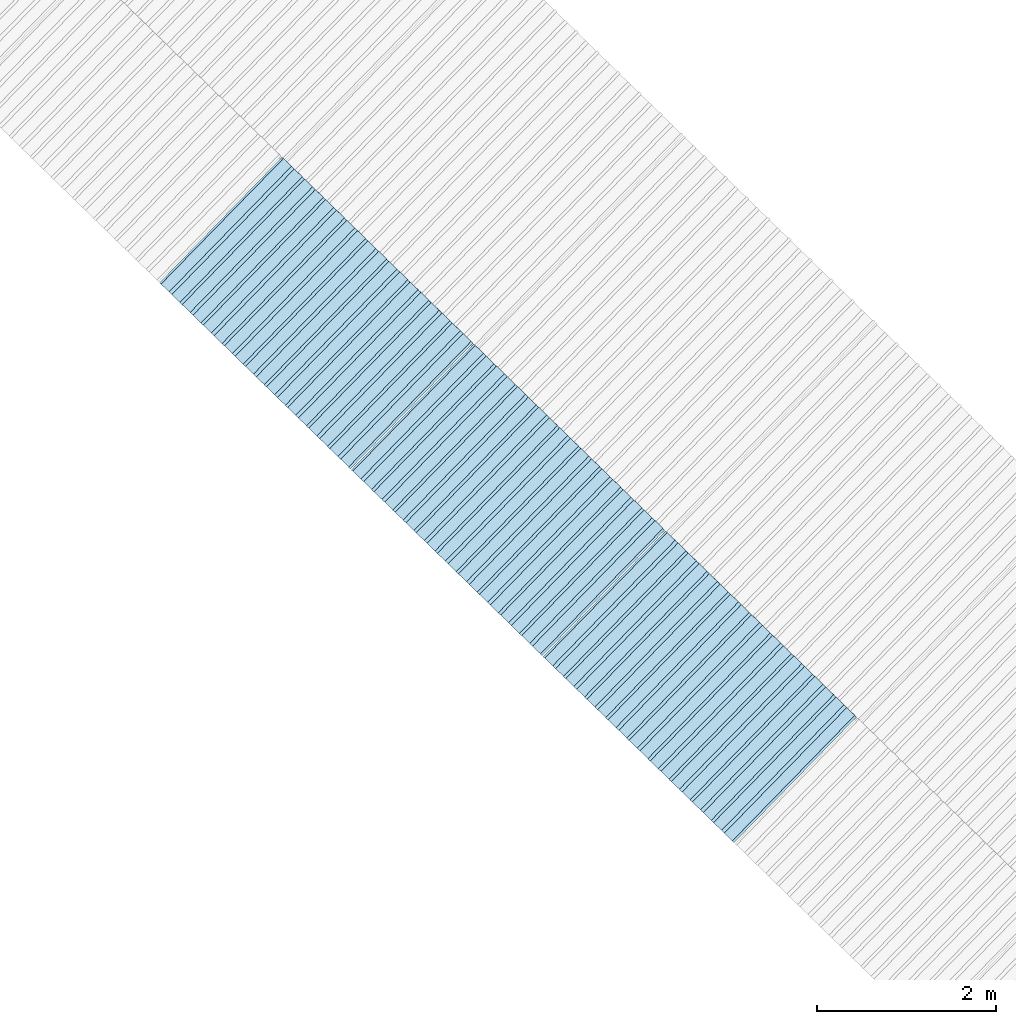
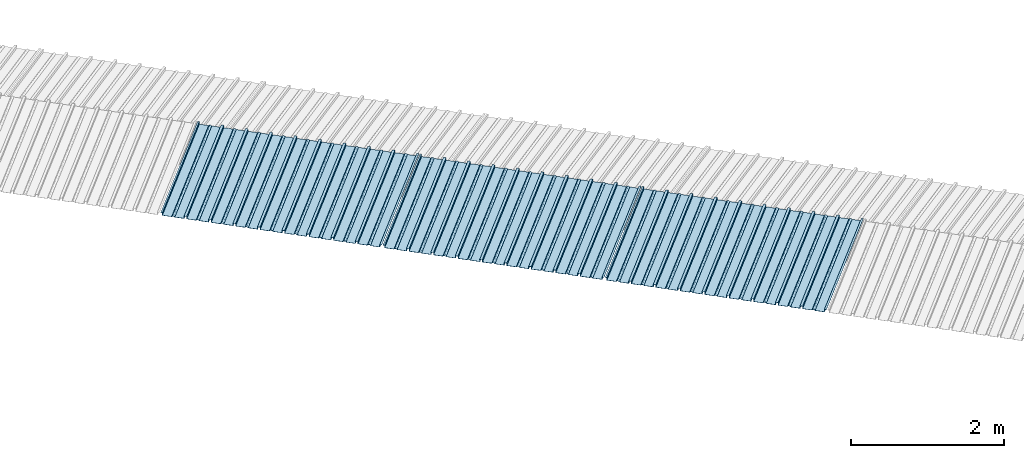
# One storey, part 1 of 8: 3 plates, 1 element without a shape of its own.
"""IFC4 building model written with IfcOpenShell, lengths in metres."""

from ifc_helpers import new_model, entity, si_unit, converted_unit, direction, frame, origin, place, context, subcontext, project, spatial, line, arc, indexed_curve, outline, extrude, source, transform, mapped, material, type_object, type_shapes, element, aggregate, save


model = new_model("IFC4")

# Units and contexts
model_context = context("Model", 3, precision=1e-05, world=origin(), true_north=direction((6.123233995736766e-17, 1.0)))
body_context = subcontext(model_context, "Body", "Model", "MODEL_VIEW")
ifc_project = project(units=[si_unit("LENGTHUNIT", "METRE"), si_unit("AREAUNIT", "SQUARE_METRE"), si_unit("VOLUMEUNIT", "CUBIC_METRE"), converted_unit("PLANEANGLEUNIT", "DEGREE", entity("IfcPlaneAngleMeasure", 0.017453292519943278), si_unit("PLANEANGLEUNIT", "RADIAN"), dimensions=[0, 0, 0, 0, 0, 0, 0])], contexts=[model_context])

# Site, building, storey
site_placement = place(None, frame((0.0, 0.0, 0.0), z_axis=(0.0, 0.0, 1.0), x_axis=(0.7160934825303189, -0.6980043870045516, 0.0)))
site = spatial("IfcSite", under=ifc_project, at=site_placement, CompositionType="ELEMENT")
building_placement = place(site_placement, origin())
building = spatial("IfcBuilding", under=site, at=building_placement, CompositionType="ELEMENT")
storey_placement = place(building_placement, frame((0.0, 0.0, -1.24)))
storey = spatial("IfcBuildingStorey", under=building, at=storey_placement, Name="Livello 5", CompositionType="ELEMENT", Elevation=-1.24)

# Roof, plates
curtain_wall_type = type_object("IfcCurtainWallType", Name="Vetrata Copertura 2", PredefinedType="NOTDEFINED")
roof_placement = place(storey_placement, frame((0.0, 0.0, 1.24)))
roof = element("IfcRoof", 1, at=roof_placement, inside=storey, type_object=curtain_wall_type, Name="Vetrata Copertura 2", ObjectType="Vetrata Copertura 2", PredefinedType="SHED_ROOF")
ifc_material = material(Name="Default")
plate_type_1 = type_object("IfcPlateType", Name="Pannello copertura:Pannello copertura", PredefinedType="CURTAIN_PANEL", material=ifc_material)
shared_shape_1 = source(origin(), body_context, "Body", "SweptSolid", [
    extrude(outline(indexed_curve([(1.339910560042256, -0.015785714285718594), (1.4699105600422562, -0.015785714285719003), (1.4699105600422562, 0.024214285714281004), (1.494919197675959, 0.02421428571428092), (1.494919197675959, 0.027214285714280917), (1.466910560042256, 0.027214285714281014), (1.466910560042256, -0.012785714285718995), (1.3417510978483753, -0.012785714285718492), (1.3199105600422556, 4.9134324369942785e-05), (1.2980700222361363, -0.012785714285718328), (1.1729105600422558, -0.01278571428571804), (1.1729105600422558, 0.02721428571428197), (1.136910560042256, 0.027214285714282097), (1.136910560042256, -0.012785714285717937), (1.0117510978483748, -0.01278571428571754), (0.9899105600422554, 4.913432437100935e-05), (0.968070022236136, -0.01278571428571726), (0.8429105600422558, -0.012785714285716971), (0.842910560042256, 0.027214285714283023), (0.8069105600422554, 0.027214285714283144), (0.8069105600422554, -0.01278571428571687), (0.6817510978483748, -0.012785714285716475), (0.6599105600422555, 4.9134324372075926e-05), (0.6380700222361361, -0.012785714285716196), (0.5129105600422553, -0.012785714285715915), (0.5129105600422554, 0.027214285714284105), (0.47691056004225557, 0.027214285714284227), (0.47691056004225557, -0.012785714285715804), (0.3517510978483749, -0.012785714285715427), (0.32991056004225544, 4.9134324373142496e-05), (0.3080700222361361, -0.012785714285715127), (0.18291056004225528, -0.012785714285714848), (0.18291056004225553, 0.027214285714285157), (0.1469105600422553, 0.02721428571428528), (0.14691056004225533, -0.012785714285714738), (0.021751097848374697, -0.01278571428571434), (-8.943995774469983e-05, 4.913432437420907e-05), (-0.021929977763864118, -0.01278571428571406), (-0.1470894399577447, -0.012785714285713783), (-0.14708943995774473, 0.02721428571428624), (-0.18308943995774493, 0.027214285714286364), (-0.1830894399577449, -0.012785714285713672), (-0.30824890215162537, -0.012785714285713215), (-0.33008943995774487, 4.9134324375275644e-05), (-0.3519299777638641, -0.012785714285712995), (-0.47708943995774494, -0.012785714285712714), (-0.4770894399577447, 0.02721428571428729), (-0.5130894399577449, 0.02721428571428741), (-0.5130894399577449, -0.012785714285712603), (-0.6382489021516256, -0.012785714285712207), (-0.6600894399577448, 4.9134324376342214e-05), (-0.6819299777638644, -0.012785714285711926), (-0.8070894399577453, -0.012785714285711647), (-0.807089439957745, 0.027214285714288373), (-0.843089439957745, 0.027214285714288494), (-0.8430894399577447, -0.012785714285711538), (-0.968248902151626, -0.012785714285711083), (-0.9900894399577453, 4.9134324377408785e-05), (-1.0119299777638646, -0.012785714285710861), (-1.1370894399577456, -0.012785714285710582), (-1.1370894399577451, 0.02721428571428942), (-1.1730894399577452, 0.027214285714289545), (-1.1730894399577454, -0.012785714285710473), (-1.2982489021516257, -0.012785714285710093), (-1.3200894399577452, 4.9134324378475355e-05), (-1.3419299777638647, -0.012785714285709794), (-1.4670894399577457, -0.012785714285709513), (-1.4670894399577454, 0.027214285714290503), (-1.490089439957745, 0.027214285714290586), (-1.490089439957745, 0.024214285714290556), (-1.4700894399577447, 0.02421428571429049), (-1.4700894399577449, -0.015785714285709514), (-1.3400894399577452, -0.015785714285709924), (-1.3200894399577452, -0.0029508656756215236), (-1.3000894399577452, -0.015785714285710063), (-1.170089439957745, -0.015785714285710472), (-1.1700894399577453, 0.024214285714289543), (-1.140089439957745, 0.02421428571428944), (-1.1400894399577455, -0.015785714285710583), (-1.0100894399577454, -0.015785714285710992), (-0.9900894399577453, -0.00295086567562259), (-0.9700894399577453, -0.015785714285711128), (-0.8400894399577448, -0.01578571428571154), (-0.8400894399577451, 0.024214285714288453), (-0.8100894399577452, 0.024214285714288356), (-0.8100894399577452, -0.015785714285711648), (-0.6800894399577451, -0.015785714285712012), (-0.6600894399577448, -0.0029508656756236573), (-0.6400894399577448, -0.015785714285712196), (-0.5100894399577451, -0.015785714285712606), (-0.5100894399577451, 0.024214285714287406), (-0.4800894399577449, 0.024214285714287305), (-0.4800894399577449, -0.015785714285712713), (-0.350089439957745, -0.01578571428571316), (-0.33008943995774487, -0.0029508656756247237), (-0.31008943995774485, -0.01578571428571326), (-0.1800894399577448, -0.015785714285713674), (-0.1800894399577448, 0.024214285714286323), (-0.1500894399577446, 0.02421428571428622), (-0.15008943995774485, -0.015785714285713782), (-0.020089439957744877, -0.015785714285714264), (-8.943995774473269e-05, -0.00295086567562579), (0.01991056004225521, -0.015785714285714323), (0.14991056004225545, -0.01578571428571474), (0.14991056004225542, 0.024214285714285272), (0.17991056004225567, 0.02421428571428517), (0.1799105600422554, -0.01578571428571485), (0.30991056004225526, -0.01578571428571532), (0.32991056004225544, -0.0029508656756268565), (0.3499105600422554, -0.015785714285715395), (0.47991056004225535, -0.015785714285715804), (0.47991056004225535, 0.02421428571428419), (0.5099105600422553, 0.02421428571428409), (0.5099105600422552, -0.015785714285715916), (0.6399105600422554, -0.015785714285716325), (0.6599105600422555, -0.002950865675627923), (0.6799105600422555, -0.01578571428571646), (0.8099105600422557, -0.015785714285716873), (0.8099105600422557, 0.02421428571428314), (0.8399105600422555, 0.02421428571428304), (0.8399105600422554, -0.015785714285716974), (0.9699105600422554, -0.015785714285717393), (0.9899105600422554, -0.0029508656756289894), (1.0099105600422555, -0.01578571428571753), (1.1399105600422557, -0.015785714285717938), (1.1399105600422557, 0.024214285714282077), (1.169910560042256, 0.024214285714281972), (1.1699105600422557, -0.01578571428571804), (1.2999105600422558, -0.01578571428571846), (1.3199105600422558, -0.0029508656756300567)], segments=[line(1, 2, 3, 4, 5, 6, 7, 8), arc(8, 9, 10), line(10, 11, 12, 13, 14, 15), arc(15, 16, 17), line(17, 18, 19, 20, 21, 22), arc(22, 23, 24), line(24, 25, 26, 27, 28, 29), arc(29, 30, 31), line(31, 32, 33, 34, 35, 36), arc(36, 37, 38), line(38, 39, 40, 41, 42, 43), arc(43, 44, 45), line(45, 46, 47, 48, 49, 50), arc(50, 51, 52), line(52, 53, 54, 55, 56, 57), arc(57, 58, 59), line(59, 60, 61, 62, 63, 64), arc(64, 65, 66), line(66, 67, 68, 69, 70, 71, 72, 73), arc(73, 74, 75), line(75, 76, 77, 78, 79, 80), arc(80, 81, 82), line(82, 83, 84, 85, 86, 87), arc(87, 88, 89), line(89, 90, 91, 92, 93, 94), arc(94, 95, 96), line(96, 97, 98, 99, 100, 101), arc(101, 102, 103), line(103, 104, 105, 106, 107, 108), arc(108, 109, 110), line(110, 111, 112, 113, 114, 115), arc(115, 116, 117), line(117, 118, 119, 120, 121, 122), arc(122, 123, 124), line(124, 125, 126, 127, 128, 129), arc(129, 130, 1)], self_intersect=False)), frame((8.080232403624576e-05, -0.015785714285719014, 0.0), z_axis=(0.0, 0.0, -1.0), x_axis=(1.0, 0.0, 0.0)), (0.0, 0.0, -1.0), 1.9691142879617602),
])
type_shapes(plate_type_1, [shared_shape_1])
plate_1_placement = place(roof_placement, frame((-11.232115726538199, -6.922854376535778, -1.0800000000000003), z_axis=(0.0, 0.9980594686585702, 0.0622679453729828), x_axis=(1.0, 0.0, 0.0)))
plate_1 = element("IfcPlate", 2, at=plate_1_placement, type_object=plate_type_1, material=ifc_material, Name="Pannello copertura:Pannello copertura", ObjectType="Pannello copertura:Pannello copertura", PredefinedType="CURTAIN_PANEL", context=body_context, shape_type="MappedRepresentation", body=[
    mapped(shared_shape_1, transform((0.0, 0.0, 0.0), scale=1.0)),
])
plate_type_2 = type_object("IfcPlateType", Name="Pannello copertura:Pannello copertura", PredefinedType="CURTAIN_PANEL", material=ifc_material)
shared_shape_2 = source(origin(), body_context, "Body", "SweptSolid", [
    extrude(outline(indexed_curve([(1.339910560042256, -0.015785714285718594), (1.4699105600422562, -0.015785714285719003), (1.4699105600422562, 0.024214285714281004), (1.494919197675959, 0.02421428571428092), (1.494919197675959, 0.027214285714280917), (1.466910560042256, 0.027214285714281014), (1.466910560042256, -0.012785714285718995), (1.3417510978483753, -0.012785714285718492), (1.3199105600422556, 4.9134324369942785e-05), (1.2980700222361363, -0.012785714285718328), (1.1729105600422558, -0.01278571428571804), (1.1729105600422558, 0.02721428571428197), (1.136910560042256, 0.027214285714282097), (1.136910560042256, -0.012785714285717937), (1.0117510978483748, -0.01278571428571754), (0.9899105600422554, 4.913432437100935e-05), (0.968070022236136, -0.01278571428571726), (0.8429105600422558, -0.012785714285716971), (0.842910560042256, 0.027214285714283023), (0.8069105600422554, 0.027214285714283144), (0.8069105600422554, -0.01278571428571687), (0.6817510978483748, -0.012785714285716475), (0.6599105600422555, 4.9134324372075926e-05), (0.6380700222361361, -0.012785714285716196), (0.5129105600422553, -0.012785714285715915), (0.5129105600422554, 0.027214285714284105), (0.47691056004225557, 0.027214285714284227), (0.47691056004225557, -0.012785714285715804), (0.3517510978483749, -0.012785714285715427), (0.32991056004225544, 4.9134324373142496e-05), (0.3080700222361361, -0.012785714285715127), (0.18291056004225528, -0.012785714285714848), (0.18291056004225553, 0.027214285714285157), (0.1469105600422553, 0.02721428571428528), (0.14691056004225533, -0.012785714285714738), (0.021751097848374697, -0.01278571428571434), (-8.943995774469983e-05, 4.913432437420907e-05), (-0.021929977763864118, -0.01278571428571406), (-0.1470894399577447, -0.012785714285713783), (-0.14708943995774473, 0.02721428571428624), (-0.18308943995774493, 0.027214285714286364), (-0.1830894399577449, -0.012785714285713672), (-0.30824890215162537, -0.012785714285713215), (-0.33008943995774487, 4.9134324375275644e-05), (-0.3519299777638641, -0.012785714285712995), (-0.47708943995774494, -0.012785714285712714), (-0.4770894399577447, 0.02721428571428729), (-0.5130894399577449, 0.02721428571428741), (-0.5130894399577449, -0.012785714285712603), (-0.6382489021516256, -0.012785714285712207), (-0.6600894399577448, 4.9134324376342214e-05), (-0.6819299777638644, -0.012785714285711926), (-0.8070894399577453, -0.012785714285711647), (-0.807089439957745, 0.027214285714288373), (-0.843089439957745, 0.027214285714288494), (-0.8430894399577447, -0.012785714285711538), (-0.968248902151626, -0.012785714285711083), (-0.9900894399577453, 4.9134324377408785e-05), (-1.0119299777638646, -0.012785714285710861), (-1.1370894399577456, -0.012785714285710582), (-1.1370894399577451, 0.02721428571428942), (-1.1730894399577452, 0.027214285714289545), (-1.1730894399577454, -0.012785714285710473), (-1.2982489021516257, -0.012785714285710093), (-1.3200894399577452, 4.9134324378475355e-05), (-1.3419299777638647, -0.012785714285709794), (-1.4670894399577457, -0.012785714285709513), (-1.4670894399577454, 0.027214285714290503), (-1.490089439957745, 0.027214285714290586), (-1.490089439957745, 0.024214285714290556), (-1.4700894399577447, 0.02421428571429049), (-1.4700894399577449, -0.015785714285709514), (-1.3400894399577452, -0.015785714285709924), (-1.3200894399577452, -0.0029508656756215236), (-1.3000894399577452, -0.015785714285710063), (-1.170089439957745, -0.015785714285710472), (-1.1700894399577453, 0.024214285714289543), (-1.140089439957745, 0.02421428571428944), (-1.1400894399577455, -0.015785714285710583), (-1.0100894399577454, -0.015785714285710992), (-0.9900894399577453, -0.00295086567562259), (-0.9700894399577453, -0.015785714285711128), (-0.8400894399577448, -0.01578571428571154), (-0.8400894399577451, 0.024214285714288453), (-0.8100894399577452, 0.024214285714288356), (-0.8100894399577452, -0.015785714285711648), (-0.6800894399577451, -0.015785714285712012), (-0.6600894399577448, -0.0029508656756236573), (-0.6400894399577448, -0.015785714285712196), (-0.5100894399577451, -0.015785714285712606), (-0.5100894399577451, 0.024214285714287406), (-0.4800894399577449, 0.024214285714287305), (-0.4800894399577449, -0.015785714285712713), (-0.350089439957745, -0.01578571428571316), (-0.33008943995774487, -0.0029508656756247237), (-0.31008943995774485, -0.01578571428571326), (-0.1800894399577448, -0.015785714285713674), (-0.1800894399577448, 0.024214285714286323), (-0.1500894399577446, 0.02421428571428622), (-0.15008943995774485, -0.015785714285713782), (-0.020089439957744877, -0.015785714285714264), (-8.943995774473269e-05, -0.00295086567562579), (0.01991056004225521, -0.015785714285714323), (0.14991056004225545, -0.01578571428571474), (0.14991056004225542, 0.024214285714285272), (0.17991056004225567, 0.02421428571428517), (0.1799105600422554, -0.01578571428571485), (0.30991056004225526, -0.01578571428571532), (0.32991056004225544, -0.0029508656756268565), (0.3499105600422554, -0.015785714285715395), (0.47991056004225535, -0.015785714285715804), (0.47991056004225535, 0.02421428571428419), (0.5099105600422553, 0.02421428571428409), (0.5099105600422552, -0.015785714285715916), (0.6399105600422554, -0.015785714285716325), (0.6599105600422555, -0.002950865675627923), (0.6799105600422555, -0.01578571428571646), (0.8099105600422557, -0.015785714285716873), (0.8099105600422557, 0.02421428571428314), (0.8399105600422555, 0.02421428571428304), (0.8399105600422554, -0.015785714285716974), (0.9699105600422554, -0.015785714285717393), (0.9899105600422554, -0.0029508656756289894), (1.0099105600422555, -0.01578571428571753), (1.1399105600422557, -0.015785714285717938), (1.1399105600422557, 0.024214285714282077), (1.169910560042256, 0.024214285714281972), (1.1699105600422557, -0.01578571428571804), (1.2999105600422558, -0.01578571428571846), (1.3199105600422558, -0.0029508656756300567)], segments=[line(1, 2, 3, 4, 5, 6, 7, 8), arc(8, 9, 10), line(10, 11, 12, 13, 14, 15), arc(15, 16, 17), line(17, 18, 19, 20, 21, 22), arc(22, 23, 24), line(24, 25, 26, 27, 28, 29), arc(29, 30, 31), line(31, 32, 33, 34, 35, 36), arc(36, 37, 38), line(38, 39, 40, 41, 42, 43), arc(43, 44, 45), line(45, 46, 47, 48, 49, 50), arc(50, 51, 52), line(52, 53, 54, 55, 56, 57), arc(57, 58, 59), line(59, 60, 61, 62, 63, 64), arc(64, 65, 66), line(66, 67, 68, 69, 70, 71, 72, 73), arc(73, 74, 75), line(75, 76, 77, 78, 79, 80), arc(80, 81, 82), line(82, 83, 84, 85, 86, 87), arc(87, 88, 89), line(89, 90, 91, 92, 93, 94), arc(94, 95, 96), line(96, 97, 98, 99, 100, 101), arc(101, 102, 103), line(103, 104, 105, 106, 107, 108), arc(108, 109, 110), line(110, 111, 112, 113, 114, 115), arc(115, 116, 117), line(117, 118, 119, 120, 121, 122), arc(122, 123, 124), line(124, 125, 126, 127, 128, 129), arc(129, 130, 1)], self_intersect=False)), frame((8.080232403624576e-05, -0.015785714285719014, 0.0), z_axis=(0.0, 0.0, -1.0), x_axis=(1.0, 0.0, 0.0)), (0.0, 0.0, -1.0), 1.9691142879617602),
])
type_shapes(plate_type_2, [shared_shape_2])
plate_2_placement = place(roof_placement, frame((-8.232110386186008, -6.922854376535778, -1.0800000000000003), z_axis=(0.0, 0.9980594686585702, 0.0622679453729828), x_axis=(1.0, 0.0, 0.0)))
plate_2 = element("IfcPlate", 3, at=plate_2_placement, type_object=plate_type_2, material=ifc_material, Name="Pannello copertura:Pannello copertura", ObjectType="Pannello copertura:Pannello copertura", PredefinedType="CURTAIN_PANEL", context=body_context, shape_type="MappedRepresentation", body=[
    mapped(shared_shape_2, transform((0.0, 0.0, 0.0), scale=1.0)),
])
plate_type_3 = type_object("IfcPlateType", Name="Pannello copertura:Pannello copertura", PredefinedType="CURTAIN_PANEL", material=ifc_material)
shared_shape_3 = source(origin(), body_context, "Body", "SweptSolid", [
    extrude(outline(indexed_curve([(1.339910560042256, -0.015785714285718594), (1.4699105600422562, -0.015785714285719003), (1.4699105600422562, 0.024214285714281004), (1.494919197675959, 0.02421428571428092), (1.494919197675959, 0.027214285714280917), (1.466910560042256, 0.027214285714281014), (1.466910560042256, -0.012785714285718995), (1.3417510978483753, -0.012785714285718492), (1.3199105600422556, 4.9134324369942785e-05), (1.2980700222361363, -0.012785714285718328), (1.1729105600422558, -0.01278571428571804), (1.1729105600422558, 0.02721428571428197), (1.136910560042256, 0.027214285714282097), (1.136910560042256, -0.012785714285717937), (1.0117510978483748, -0.01278571428571754), (0.9899105600422554, 4.913432437100935e-05), (0.968070022236136, -0.01278571428571726), (0.8429105600422558, -0.012785714285716971), (0.842910560042256, 0.027214285714283023), (0.8069105600422554, 0.027214285714283144), (0.8069105600422554, -0.01278571428571687), (0.6817510978483748, -0.012785714285716475), (0.6599105600422555, 4.9134324372075926e-05), (0.6380700222361361, -0.012785714285716196), (0.5129105600422553, -0.012785714285715915), (0.5129105600422554, 0.027214285714284105), (0.47691056004225557, 0.027214285714284227), (0.47691056004225557, -0.012785714285715804), (0.3517510978483749, -0.012785714285715427), (0.32991056004225544, 4.9134324373142496e-05), (0.3080700222361361, -0.012785714285715127), (0.18291056004225528, -0.012785714285714848), (0.18291056004225553, 0.027214285714285157), (0.1469105600422553, 0.02721428571428528), (0.14691056004225533, -0.012785714285714738), (0.021751097848374697, -0.01278571428571434), (-8.943995774469983e-05, 4.913432437420907e-05), (-0.021929977763864118, -0.01278571428571406), (-0.1470894399577447, -0.012785714285713783), (-0.14708943995774473, 0.02721428571428624), (-0.18308943995774493, 0.027214285714286364), (-0.1830894399577449, -0.012785714285713672), (-0.30824890215162537, -0.012785714285713215), (-0.33008943995774487, 4.9134324375275644e-05), (-0.3519299777638641, -0.012785714285712995), (-0.47708943995774494, -0.012785714285712714), (-0.4770894399577447, 0.02721428571428729), (-0.5130894399577449, 0.02721428571428741), (-0.5130894399577449, -0.012785714285712603), (-0.6382489021516256, -0.012785714285712207), (-0.6600894399577448, 4.9134324376342214e-05), (-0.6819299777638644, -0.012785714285711926), (-0.8070894399577453, -0.012785714285711647), (-0.807089439957745, 0.027214285714288373), (-0.843089439957745, 0.027214285714288494), (-0.8430894399577447, -0.012785714285711538), (-0.968248902151626, -0.012785714285711083), (-0.9900894399577453, 4.9134324377408785e-05), (-1.0119299777638646, -0.012785714285710861), (-1.1370894399577456, -0.012785714285710582), (-1.1370894399577451, 0.02721428571428942), (-1.1730894399577452, 0.027214285714289545), (-1.1730894399577454, -0.012785714285710473), (-1.2982489021516257, -0.012785714285710093), (-1.3200894399577452, 4.9134324378475355e-05), (-1.3419299777638647, -0.012785714285709794), (-1.4670894399577457, -0.012785714285709513), (-1.4670894399577454, 0.027214285714290503), (-1.490089439957745, 0.027214285714290586), (-1.490089439957745, 0.024214285714290556), (-1.4700894399577447, 0.02421428571429049), (-1.4700894399577449, -0.015785714285709514), (-1.3400894399577452, -0.015785714285709924), (-1.3200894399577452, -0.0029508656756215236), (-1.3000894399577452, -0.015785714285710063), (-1.170089439957745, -0.015785714285710472), (-1.1700894399577453, 0.024214285714289543), (-1.140089439957745, 0.02421428571428944), (-1.1400894399577455, -0.015785714285710583), (-1.0100894399577454, -0.015785714285710992), (-0.9900894399577453, -0.00295086567562259), (-0.9700894399577453, -0.015785714285711128), (-0.8400894399577448, -0.01578571428571154), (-0.8400894399577451, 0.024214285714288453), (-0.8100894399577452, 0.024214285714288356), (-0.8100894399577452, -0.015785714285711648), (-0.6800894399577451, -0.015785714285712012), (-0.6600894399577448, -0.0029508656756236573), (-0.6400894399577448, -0.015785714285712196), (-0.5100894399577451, -0.015785714285712606), (-0.5100894399577451, 0.024214285714287406), (-0.4800894399577449, 0.024214285714287305), (-0.4800894399577449, -0.015785714285712713), (-0.350089439957745, -0.01578571428571316), (-0.33008943995774487, -0.0029508656756247237), (-0.31008943995774485, -0.01578571428571326), (-0.1800894399577448, -0.015785714285713674), (-0.1800894399577448, 0.024214285714286323), (-0.1500894399577446, 0.02421428571428622), (-0.15008943995774485, -0.015785714285713782), (-0.020089439957744877, -0.015785714285714264), (-8.943995774473269e-05, -0.00295086567562579), (0.01991056004225521, -0.015785714285714323), (0.14991056004225545, -0.01578571428571474), (0.14991056004225542, 0.024214285714285272), (0.17991056004225567, 0.02421428571428517), (0.1799105600422554, -0.01578571428571485), (0.30991056004225526, -0.01578571428571532), (0.32991056004225544, -0.0029508656756268565), (0.3499105600422554, -0.015785714285715395), (0.47991056004225535, -0.015785714285715804), (0.47991056004225535, 0.02421428571428419), (0.5099105600422553, 0.02421428571428409), (0.5099105600422552, -0.015785714285715916), (0.6399105600422554, -0.015785714285716325), (0.6599105600422555, -0.002950865675627923), (0.6799105600422555, -0.01578571428571646), (0.8099105600422557, -0.015785714285716873), (0.8099105600422557, 0.02421428571428314), (0.8399105600422555, 0.02421428571428304), (0.8399105600422554, -0.015785714285716974), (0.9699105600422554, -0.015785714285717393), (0.9899105600422554, -0.0029508656756289894), (1.0099105600422555, -0.01578571428571753), (1.1399105600422557, -0.015785714285717938), (1.1399105600422557, 0.024214285714282077), (1.169910560042256, 0.024214285714281972), (1.1699105600422557, -0.01578571428571804), (1.2999105600422558, -0.01578571428571846), (1.3199105600422558, -0.0029508656756300567)], segments=[line(1, 2, 3, 4, 5, 6, 7, 8), arc(8, 9, 10), line(10, 11, 12, 13, 14, 15), arc(15, 16, 17), line(17, 18, 19, 20, 21, 22), arc(22, 23, 24), line(24, 25, 26, 27, 28, 29), arc(29, 30, 31), line(31, 32, 33, 34, 35, 36), arc(36, 37, 38), line(38, 39, 40, 41, 42, 43), arc(43, 44, 45), line(45, 46, 47, 48, 49, 50), arc(50, 51, 52), line(52, 53, 54, 55, 56, 57), arc(57, 58, 59), line(59, 60, 61, 62, 63, 64), arc(64, 65, 66), line(66, 67, 68, 69, 70, 71, 72, 73), arc(73, 74, 75), line(75, 76, 77, 78, 79, 80), arc(80, 81, 82), line(82, 83, 84, 85, 86, 87), arc(87, 88, 89), line(89, 90, 91, 92, 93, 94), arc(94, 95, 96), line(96, 97, 98, 99, 100, 101), arc(101, 102, 103), line(103, 104, 105, 106, 107, 108), arc(108, 109, 110), line(110, 111, 112, 113, 114, 115), arc(115, 116, 117), line(117, 118, 119, 120, 121, 122), arc(122, 123, 124), line(124, 125, 126, 127, 128, 129), arc(129, 130, 1)], self_intersect=False)), frame((8.080232403624576e-05, -0.015785714285719014, 0.0), z_axis=(0.0, 0.0, -1.0), x_axis=(1.0, 0.0, 0.0)), (0.0, 0.0, -1.0), 1.9691142879617602),
])
type_shapes(plate_type_3, [shared_shape_3])
plate_3_placement = place(roof_placement, frame((-5.2321061325444, -6.922854376535778, -1.0800000000000003), z_axis=(0.0, 0.9980594686585702, 0.0622679453729828), x_axis=(1.0, 0.0, 0.0)))
plate_3 = element("IfcPlate", 4, at=plate_3_placement, type_object=plate_type_3, material=ifc_material, Name="Pannello copertura:Pannello copertura", ObjectType="Pannello copertura:Pannello copertura", PredefinedType="CURTAIN_PANEL", context=body_context, shape_type="MappedRepresentation", body=[
    mapped(shared_shape_3, transform((0.0, 0.0, 0.0), scale=1.0)),
])
aggregate(roof, [plate_1, plate_2, plate_3])

save(model, "model.ifc")
